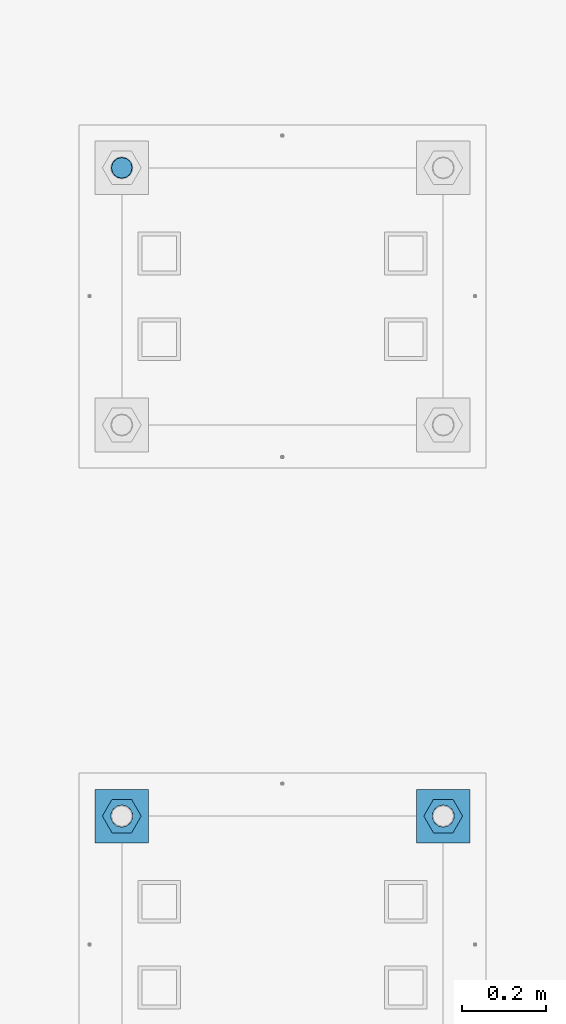
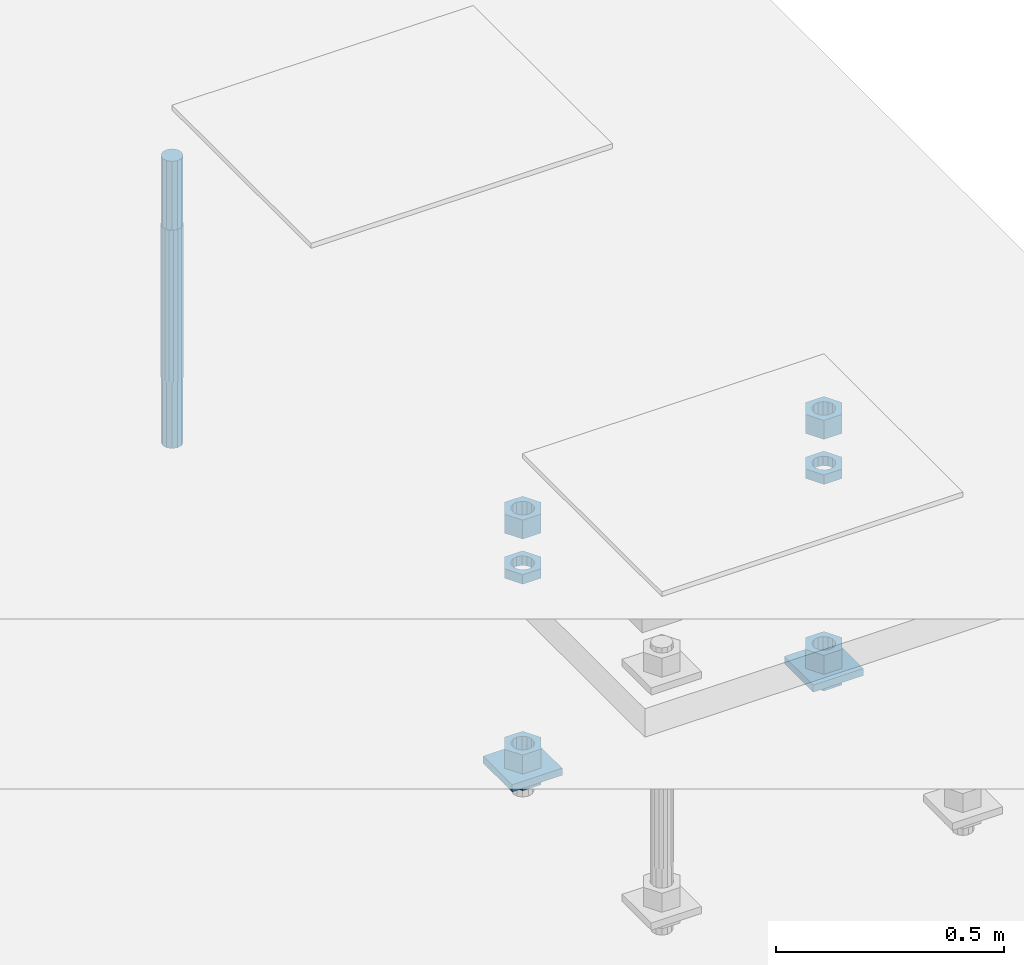
# One storey, part 2633 of 3843: 11 beams, 2 elements without a shape of their own.
"""IFC2X3 building model written with IfcOpenShell, lengths in millimetres."""

from ifc_helpers import new_model, si_unit, frame, origin_with_axes, place, context, subcontext, project, spatial, faceted_brep, material, type_object, element, aggregate, save


model = new_model("IFC2X3")

# Units and contexts
model_context = context("Model", 3, precision=1e-05, world=origin_with_axes())
body_context = subcontext(model_context, "Body", "Model", "MODEL_VIEW")
ifc_project = project(units=[si_unit("LENGTHUNIT", "METRE", prefix="MILLI"), si_unit("AREAUNIT", "SQUARE_METRE"), si_unit("VOLUMEUNIT", "CUBIC_METRE"), si_unit("MASSUNIT", "GRAM", prefix="KILO"), si_unit("TIMEUNIT", "SECOND"), si_unit("PLANEANGLEUNIT", "RADIAN"), si_unit("SOLIDANGLEUNIT", "STERADIAN"), si_unit("THERMODYNAMICTEMPERATUREUNIT", "DEGREE_CELSIUS"), si_unit("LUMINOUSINTENSITYUNIT", "LUMEN")], contexts=[model_context])

# Site, building, storey
site_placement = place(None, origin_with_axes())
site = spatial("IfcSite", under=ifc_project, at=site_placement, CompositionType="ELEMENT")
building_placement = place(site_placement, origin_with_axes())
building = spatial("IfcBuilding", under=site, at=building_placement, Name="Undefined", CompositionType="ELEMENT")
storey_placement = place(building_placement, origin_with_axes())
storey = spatial("IfcBuildingStorey", under=building, at=storey_placement, Name="Undefined", CompositionType="ELEMENT", Elevation=0.0)

# Assembly, beams
assembly_1_placement = place(storey_placement, origin_with_axes())
assembly_1 = element("IfcElementAssembly", 1, at=assembly_1_placement, inside=storey, Name="TEMPLATE", AssemblyPlace="NOTDEFINED", PredefinedType="RIGID_FRAME")
ifc_material_1 = material(Name="STEEL/A572-50")
beam_type_1 = type_object("IfcBeamType", PredefinedType="NOTDEFINED")
beam_1_placement = place(assembly_1_placement, frame((118465.6, 1892.30000152587, 29244.925), z_axis=(1.0, 0.0, 0.0), x_axis=(0.0, 1.0, 0.0)))
beam_1 = element("IfcBeam", 2, at=beam_1_placement, type_object=beam_type_1, material=ifc_material_1, Name="WASHER_PLATE", context=body_context, shape_type="Brep", body=[
    faceted_brep([(0.0, 9.52500000000146, -63.5), (0.0, 9.52500000000146, 63.5), (127.0, 9.52500000000146, 63.5), (127.0, 9.52500000000146, -63.5), (0.0, -9.52500000000146, 63.5), (127.0, -9.52500000000146, 63.5), (0.0, -9.52500000000146, -63.5), (127.0, -9.52500000000146, -63.5)], [[[0, 1, 2, 3]], [[1, 4, 5, 2]], [[4, 6, 7, 5]], [[6, 0, 3, 7]], [[5, 7, 3, 2]], [[6, 4, 1, 0]]]),
])
beam_2_placement = place(assembly_1_placement, frame((119227.6, 1892.30000152587, 29244.925), z_axis=(1.0, 0.0, 0.0), x_axis=(0.0, 1.0, 0.0)))
beam_2 = element("IfcBeam", 3, at=beam_2_placement, type_object=beam_type_1, material=ifc_material_1, Name="WASHER_PLATE", context=body_context, shape_type="Brep", body=[
    faceted_brep([(0.0, 9.52500000000146, -63.5), (0.0, 9.52500000000146, 63.5), (127.0, 9.52500000000146, 63.5), (127.0, 9.52500000000146, -63.5), (0.0, -9.52500000000146, 63.5), (127.0, -9.52500000000146, 63.5), (0.0, -9.52500000000146, -63.5), (127.0, -9.52500000000146, -63.5)], [[[0, 1, 2, 3]], [[1, 4, 5, 2]], [[4, 6, 7, 5]], [[6, 0, 3, 7]], [[5, 7, 3, 2]], [[6, 4, 1, 0]]]),
])
ifc_material_2 = material(Name="STEEL/A36")
beam_type_2 = type_object("IfcBeamType", Name="2_HALF_NUT", PredefinedType="NOTDEFINED")
beam_3_placement = place(assembly_1_placement, frame((118465.6, 1955.80000152587, 29787.85), z_axis=(0.0, 1.0, 0.0), x_axis=(0.0, 0.0, -1.0)))
beam_3 = element("IfcBeam", 4, at=beam_3_placement, type_object=beam_type_2, material=ifc_material_2, Name="NUT", ObjectType="2_HALF_NUT", context=body_context, shape_type="Brep", body=[
    faceted_brep([(0.0, -46.0369987487793, 0.0), (0.0, -23.0184993743896, -39.869213104248), (25.4000000000015, -23.0184993743896, -39.869213104248), (25.4000000000015, -46.0369987487793, 0.0), (0.0, 23.0184993743896, -39.869213104248), (25.4000000000015, 23.0184993743896, -39.869213104248), (0.0, 46.0369987487793, 0.0), (25.4000000000015, 46.0369987487793, 0.0), (0.0, 23.0184993743896, 39.869213104248), (25.4000000000015, 23.0184993743896, 39.869213104248), (0.0, -23.0184993743896, 39.869213104248), (25.4000000000015, -23.0184993743896, 39.869213104248), (0.0, 0.0, 26.1940002441406), (0.0, 11.3650617044477, 23.5999013092805), (25.4000000000015, 11.3650617044477, 23.5999013092805), (25.4000000000015, 0.0, 26.1940002441406), (0.0, 20.4791109456419, 16.3316083006721), (25.4000000000015, 20.4791109456419, 16.3316083006721), (0.0, 25.5370200498292, 5.82867859874386), (25.4000000000015, 25.5370200498292, 5.82867859874386), (0.0, 25.5370200498292, -5.82867859874386), (25.4000000000015, 25.5370200498292, -5.82867859874386), (0.0, 20.4791109456419, -16.3316083006721), (25.4000000000015, 20.4791109456419, -16.3316083006721), (0.0, 11.3650617044477, -23.5999013092805), (25.4000000000015, 11.3650617044477, -23.5999013092805), (0.0, 0.0, -26.1940002441406), (25.4000000000015, 0.0, -26.1940002441406), (0.0, -11.3650617044477, -23.5999013092805), (25.4000000000015, -11.3650617044477, -23.5999013092805), (0.0, -20.4791109456419, -16.3316083006721), (25.4000000000015, -20.4791109456419, -16.3316083006721), (0.0, -25.5370200498292, -5.82867859874386), (25.4000000000015, -25.5370200498292, -5.82867859874386), (0.0, -25.5370200498292, 5.82867859874386), (25.4000000000015, -25.5370200498292, 5.82867859874386), (0.0, -20.4791109456419, 16.3316083006721), (25.4000000000015, -20.4791109456419, 16.3316083006721), (0.0, -11.3650617044477, 23.5999013092805), (25.4000000000015, -11.3650617044477, 23.5999013092805)], [[[0, 1, 2, 3]], [[1, 4, 5, 2]], [[4, 6, 7, 5]], [[6, 8, 9, 7]], [[8, 10, 11, 9]], [[10, 0, 3, 11]], [[12, 13, 14, 15]], [[13, 16, 17, 14]], [[16, 18, 19, 17]], [[18, 20, 21, 19]], [[20, 22, 23, 21]], [[22, 24, 25, 23]], [[24, 26, 27, 25]], [[26, 28, 29, 27]], [[28, 30, 31, 29]], [[30, 32, 33, 31]], [[32, 34, 35, 33]], [[34, 36, 37, 35]], [[36, 38, 39, 37]], [[38, 12, 15, 39]], [[5, 7, 9, 11, 3, 2], [17, 19, 21, 23, 25, 27, 29, 31, 33, 35, 37, 39, 15, 14]], [[10, 8, 6, 4, 1, 0], [38, 36, 34, 32, 30, 28, 26, 24, 22, 20, 18, 16, 13, 12]]]),
])
beam_4_placement = place(assembly_1_placement, frame((118465.6, 1955.80000152587, 29235.4), z_axis=(0.0, 1.0, 0.0), x_axis=(0.0, 0.0, -1.0)))
beam_4 = element("IfcBeam", 5, at=beam_4_placement, type_object=beam_type_2, material=ifc_material_2, Name="NUT", ObjectType="2_HALF_NUT", context=body_context, shape_type="Brep", body=[
    faceted_brep([(0.0, -46.0369987487793, 0.0), (0.0, -23.0184993743896, -39.869213104248), (25.4000000000015, -23.0184993743896, -39.869213104248), (25.4000000000015, -46.0369987487793, 0.0), (0.0, 23.0184993743896, -39.869213104248), (25.4000000000015, 23.0184993743896, -39.869213104248), (0.0, 46.0369987487793, 0.0), (25.4000000000015, 46.0369987487793, 0.0), (0.0, 23.0184993743896, 39.869213104248), (25.4000000000015, 23.0184993743896, 39.869213104248), (0.0, -23.0184993743896, 39.869213104248), (25.4000000000015, -23.0184993743896, 39.869213104248), (0.0, 0.0, 26.1940002441406), (0.0, 11.3650617044477, 23.5999013092805), (25.4000000000015, 11.3650617044477, 23.5999013092805), (25.4000000000015, 0.0, 26.1940002441406), (0.0, 20.4791109456419, 16.3316083006721), (25.4000000000015, 20.4791109456419, 16.3316083006721), (0.0, 25.5370200498292, 5.82867859874386), (25.4000000000015, 25.5370200498292, 5.82867859874386), (0.0, 25.5370200498292, -5.82867859874386), (25.4000000000015, 25.5370200498292, -5.82867859874386), (0.0, 20.4791109456419, -16.3316083006721), (25.4000000000015, 20.4791109456419, -16.3316083006721), (0.0, 11.3650617044477, -23.5999013092805), (25.4000000000015, 11.3650617044477, -23.5999013092805), (0.0, 0.0, -26.1940002441406), (25.4000000000015, 0.0, -26.1940002441406), (0.0, -11.3650617044477, -23.5999013092805), (25.4000000000015, -11.3650617044477, -23.5999013092805), (0.0, -20.4791109456419, -16.3316083006721), (25.4000000000015, -20.4791109456419, -16.3316083006721), (0.0, -25.5370200498292, -5.82867859874386), (25.4000000000015, -25.5370200498292, -5.82867859874386), (0.0, -25.5370200498292, 5.82867859874386), (25.4000000000015, -25.5370200498292, 5.82867859874386), (0.0, -20.4791109456419, 16.3316083006721), (25.4000000000015, -20.4791109456419, 16.3316083006721), (0.0, -11.3650617044477, 23.5999013092805), (25.4000000000015, -11.3650617044477, 23.5999013092805)], [[[0, 1, 2, 3]], [[1, 4, 5, 2]], [[4, 6, 7, 5]], [[6, 8, 9, 7]], [[8, 10, 11, 9]], [[10, 0, 3, 11]], [[12, 13, 14, 15]], [[13, 16, 17, 14]], [[16, 18, 19, 17]], [[18, 20, 21, 19]], [[20, 22, 23, 21]], [[22, 24, 25, 23]], [[24, 26, 27, 25]], [[26, 28, 29, 27]], [[28, 30, 31, 29]], [[30, 32, 33, 31]], [[32, 34, 35, 33]], [[34, 36, 37, 35]], [[36, 38, 39, 37]], [[38, 12, 15, 39]], [[5, 7, 9, 11, 3, 2], [17, 19, 21, 23, 25, 27, 29, 31, 33, 35, 37, 39, 15, 14]], [[10, 8, 6, 4, 1, 0], [38, 36, 34, 32, 30, 28, 26, 24, 22, 20, 18, 16, 13, 12]]]),
])
beam_5_placement = place(assembly_1_placement, frame((119227.6, 1955.80000152587, 29787.85), z_axis=(0.0, 1.0, 0.0), x_axis=(0.0, 0.0, -1.0)))
beam_5 = element("IfcBeam", 6, at=beam_5_placement, type_object=beam_type_2, material=ifc_material_2, Name="NUT", ObjectType="2_HALF_NUT", context=body_context, shape_type="Brep", body=[
    faceted_brep([(0.0, -46.0369987487793, 0.0), (0.0, -23.0184993743896, -39.869213104248), (25.4000000000015, -23.0184993743896, -39.869213104248), (25.4000000000015, -46.0369987487793, 0.0), (0.0, 23.0184993743896, -39.869213104248), (25.4000000000015, 23.0184993743896, -39.869213104248), (0.0, 46.0369987487793, 0.0), (25.4000000000015, 46.0369987487793, 0.0), (0.0, 23.0184993743896, 39.869213104248), (25.4000000000015, 23.0184993743896, 39.869213104248), (0.0, -23.0184993743896, 39.869213104248), (25.4000000000015, -23.0184993743896, 39.869213104248), (0.0, 0.0, 26.1940002441406), (0.0, 11.3650617044477, 23.5999013092805), (25.4000000000015, 11.3650617044477, 23.5999013092805), (25.4000000000015, 0.0, 26.1940002441406), (0.0, 20.4791109456419, 16.3316083006721), (25.4000000000015, 20.4791109456419, 16.3316083006721), (0.0, 25.5370200498292, 5.82867859874386), (25.4000000000015, 25.5370200498292, 5.82867859874386), (0.0, 25.5370200498292, -5.82867859874386), (25.4000000000015, 25.5370200498292, -5.82867859874386), (0.0, 20.4791109456419, -16.3316083006721), (25.4000000000015, 20.4791109456419, -16.3316083006721), (0.0, 11.3650617044477, -23.5999013092805), (25.4000000000015, 11.3650617044477, -23.5999013092805), (0.0, 0.0, -26.1940002441406), (25.4000000000015, 0.0, -26.1940002441406), (0.0, -11.3650617044477, -23.5999013092805), (25.4000000000015, -11.3650617044477, -23.5999013092805), (0.0, -20.4791109456419, -16.3316083006721), (25.4000000000015, -20.4791109456419, -16.3316083006721), (0.0, -25.5370200498292, -5.82867859874386), (25.4000000000015, -25.5370200498292, -5.82867859874386), (0.0, -25.5370200498292, 5.82867859874386), (25.4000000000015, -25.5370200498292, 5.82867859874386), (0.0, -20.4791109456419, 16.3316083006721), (25.4000000000015, -20.4791109456419, 16.3316083006721), (0.0, -11.3650617044477, 23.5999013092805), (25.4000000000015, -11.3650617044477, 23.5999013092805)], [[[0, 1, 2, 3]], [[1, 4, 5, 2]], [[4, 6, 7, 5]], [[6, 8, 9, 7]], [[8, 10, 11, 9]], [[10, 0, 3, 11]], [[12, 13, 14, 15]], [[13, 16, 17, 14]], [[16, 18, 19, 17]], [[18, 20, 21, 19]], [[20, 22, 23, 21]], [[22, 24, 25, 23]], [[24, 26, 27, 25]], [[26, 28, 29, 27]], [[28, 30, 31, 29]], [[30, 32, 33, 31]], [[32, 34, 35, 33]], [[34, 36, 37, 35]], [[36, 38, 39, 37]], [[38, 12, 15, 39]], [[5, 7, 9, 11, 3, 2], [17, 19, 21, 23, 25, 27, 29, 31, 33, 35, 37, 39, 15, 14]], [[10, 8, 6, 4, 1, 0], [38, 36, 34, 32, 30, 28, 26, 24, 22, 20, 18, 16, 13, 12]]]),
])
beam_6_placement = place(assembly_1_placement, frame((119227.6, 1955.80000152587, 29235.4), z_axis=(0.0, 1.0, 0.0), x_axis=(0.0, 0.0, -1.0)))
beam_6 = element("IfcBeam", 7, at=beam_6_placement, type_object=beam_type_2, material=ifc_material_2, Name="NUT", ObjectType="2_HALF_NUT", context=body_context, shape_type="Brep", body=[
    faceted_brep([(0.0, -46.0369987487793, 0.0), (0.0, -23.0184993743896, -39.869213104248), (25.4000000000015, -23.0184993743896, -39.869213104248), (25.4000000000015, -46.0369987487793, 0.0), (0.0, 23.0184993743896, -39.869213104248), (25.4000000000015, 23.0184993743896, -39.869213104248), (0.0, 46.0369987487793, 0.0), (25.4000000000015, 46.0369987487793, 0.0), (0.0, 23.0184993743896, 39.869213104248), (25.4000000000015, 23.0184993743896, 39.869213104248), (0.0, -23.0184993743896, 39.869213104248), (25.4000000000015, -23.0184993743896, 39.869213104248), (0.0, 0.0, 26.1940002441406), (0.0, 11.3650617044477, 23.5999013092805), (25.4000000000015, 11.3650617044477, 23.5999013092805), (25.4000000000015, 0.0, 26.1940002441406), (0.0, 20.4791109456419, 16.3316083006721), (25.4000000000015, 20.4791109456419, 16.3316083006721), (0.0, 25.5370200498292, 5.82867859874386), (25.4000000000015, 25.5370200498292, 5.82867859874386), (0.0, 25.5370200498292, -5.82867859874386), (25.4000000000015, 25.5370200498292, -5.82867859874386), (0.0, 20.4791109456419, -16.3316083006721), (25.4000000000015, 20.4791109456419, -16.3316083006721), (0.0, 11.3650617044477, -23.5999013092805), (25.4000000000015, 11.3650617044477, -23.5999013092805), (0.0, 0.0, -26.1940002441406), (25.4000000000015, 0.0, -26.1940002441406), (0.0, -11.3650617044477, -23.5999013092805), (25.4000000000015, -11.3650617044477, -23.5999013092805), (0.0, -20.4791109456419, -16.3316083006721), (25.4000000000015, -20.4791109456419, -16.3316083006721), (0.0, -25.5370200498292, -5.82867859874386), (25.4000000000015, -25.5370200498292, -5.82867859874386), (0.0, -25.5370200498292, 5.82867859874386), (25.4000000000015, -25.5370200498292, 5.82867859874386), (0.0, -20.4791109456419, 16.3316083006721), (25.4000000000015, -20.4791109456419, 16.3316083006721), (0.0, -11.3650617044477, 23.5999013092805), (25.4000000000015, -11.3650617044477, 23.5999013092805)], [[[0, 1, 2, 3]], [[1, 4, 5, 2]], [[4, 6, 7, 5]], [[6, 8, 9, 7]], [[8, 10, 11, 9]], [[10, 0, 3, 11]], [[12, 13, 14, 15]], [[13, 16, 17, 14]], [[16, 18, 19, 17]], [[18, 20, 21, 19]], [[20, 22, 23, 21]], [[22, 24, 25, 23]], [[24, 26, 27, 25]], [[26, 28, 29, 27]], [[28, 30, 31, 29]], [[30, 32, 33, 31]], [[32, 34, 35, 33]], [[34, 36, 37, 35]], [[36, 38, 39, 37]], [[38, 12, 15, 39]], [[5, 7, 9, 11, 3, 2], [17, 19, 21, 23, 25, 27, 29, 31, 33, 35, 37, 39, 15, 14]], [[10, 8, 6, 4, 1, 0], [38, 36, 34, 32, 30, 28, 26, 24, 22, 20, 18, 16, 13, 12]]]),
])
beam_type_3 = type_object("IfcBeamType", Name="2_HEAVY_HEX_NUT", PredefinedType="NOTDEFINED")
beam_7_placement = place(assembly_1_placement, frame((118465.6, 1955.80000152587, 29933.9), z_axis=(0.0, 1.0, 0.0), x_axis=(0.0, 0.0, -1.0)))
beam_7 = element("IfcBeam", 8, at=beam_7_placement, type_object=beam_type_3, material=ifc_material_2, Name="NUT", ObjectType="2_HEAVY_HEX_NUT", context=body_context, shape_type="Brep", body=[
    faceted_brep([(0.0, -46.0369987487793, 0.0), (0.0, -23.0184993743896, -39.869213104248), (50.7999999999993, -23.0184993743896, -39.869213104248), (50.7999999999993, -46.0369987487793, 0.0), (0.0, 23.0184993743896, -39.869213104248), (50.7999999999993, 23.0184993743896, -39.869213104248), (0.0, 46.0369987487793, 0.0), (50.7999999999993, 46.0369987487793, 0.0), (0.0, 23.0184993743896, 39.869213104248), (50.7999999999993, 23.0184993743896, 39.869213104248), (0.0, -23.0184993743896, 39.869213104248), (50.7999999999993, -23.0184993743896, 39.869213104248), (0.0, 0.0, 26.1940002441406), (0.0, 11.3650617044477, 23.5999013092805), (50.7999999999993, 11.3650617044477, 23.5999013092805), (50.7999999999993, 0.0, 26.1940002441406), (0.0, 20.4791109456419, 16.3316083006721), (50.7999999999993, 20.4791109456419, 16.3316083006721), (0.0, 25.5370200498292, 5.82867859874386), (50.7999999999993, 25.5370200498292, 5.82867859874386), (0.0, 25.5370200498292, -5.82867859874386), (50.7999999999993, 25.5370200498292, -5.82867859874386), (0.0, 20.4791109456419, -16.3316083006721), (50.7999999999993, 20.4791109456419, -16.3316083006721), (0.0, 11.3650617044477, -23.5999013092805), (50.7999999999993, 11.3650617044477, -23.5999013092805), (0.0, 0.0, -26.1940002441406), (50.7999999999993, 0.0, -26.1940002441406), (0.0, -11.3650617044477, -23.5999013092805), (50.7999999999993, -11.3650617044477, -23.5999013092805), (0.0, -20.4791109456419, -16.3316083006721), (50.7999999999993, -20.4791109456419, -16.3316083006721), (0.0, -25.5370200498292, -5.82867859874386), (50.7999999999993, -25.5370200498292, -5.82867859874386), (0.0, -25.5370200498292, 5.82867859874386), (50.7999999999993, -25.5370200498292, 5.82867859874386), (0.0, -20.4791109456419, 16.3316083006721), (50.7999999999993, -20.4791109456419, 16.3316083006721), (0.0, -11.3650617044477, 23.5999013092805), (50.7999999999993, -11.3650617044477, 23.5999013092805)], [[[0, 1, 2, 3]], [[1, 4, 5, 2]], [[4, 6, 7, 5]], [[6, 8, 9, 7]], [[8, 10, 11, 9]], [[10, 0, 3, 11]], [[12, 13, 14, 15]], [[13, 16, 17, 14]], [[16, 18, 19, 17]], [[18, 20, 21, 19]], [[20, 22, 23, 21]], [[22, 24, 25, 23]], [[24, 26, 27, 25]], [[26, 28, 29, 27]], [[28, 30, 31, 29]], [[30, 32, 33, 31]], [[32, 34, 35, 33]], [[34, 36, 37, 35]], [[36, 38, 39, 37]], [[38, 12, 15, 39]], [[5, 7, 9, 11, 3, 2], [17, 19, 21, 23, 25, 27, 29, 31, 33, 35, 37, 39, 15, 14]], [[10, 8, 6, 4, 1, 0], [38, 36, 34, 32, 30, 28, 26, 24, 22, 20, 18, 16, 13, 12]]]),
])
beam_8_placement = place(assembly_1_placement, frame((118465.6, 1955.80000152587, 29305.25), z_axis=(0.0, 1.0, 0.0), x_axis=(0.0, 0.0, -1.0)))
beam_8 = element("IfcBeam", 9, at=beam_8_placement, type_object=beam_type_3, material=ifc_material_2, Name="NUT", ObjectType="2_HEAVY_HEX_NUT", context=body_context, shape_type="Brep", body=[
    faceted_brep([(0.0, -46.0369987487793, 0.0), (0.0, -23.0184993743896, -39.869213104248), (50.7999999999993, -23.0184993743896, -39.869213104248), (50.7999999999993, -46.0369987487793, 0.0), (0.0, 23.0184993743896, -39.869213104248), (50.7999999999993, 23.0184993743896, -39.869213104248), (0.0, 46.0369987487793, 0.0), (50.7999999999993, 46.0369987487793, 0.0), (0.0, 23.0184993743896, 39.869213104248), (50.7999999999993, 23.0184993743896, 39.869213104248), (0.0, -23.0184993743896, 39.869213104248), (50.7999999999993, -23.0184993743896, 39.869213104248), (0.0, 0.0, 26.1940002441406), (0.0, 11.3650617044477, 23.5999013092805), (50.7999999999993, 11.3650617044477, 23.5999013092805), (50.7999999999993, 0.0, 26.1940002441406), (0.0, 20.4791109456419, 16.3316083006721), (50.7999999999993, 20.4791109456419, 16.3316083006721), (0.0, 25.5370200498292, 5.82867859874386), (50.7999999999993, 25.5370200498292, 5.82867859874386), (0.0, 25.5370200498292, -5.82867859874386), (50.7999999999993, 25.5370200498292, -5.82867859874386), (0.0, 20.4791109456419, -16.3316083006721), (50.7999999999993, 20.4791109456419, -16.3316083006721), (0.0, 11.3650617044477, -23.5999013092805), (50.7999999999993, 11.3650617044477, -23.5999013092805), (0.0, 0.0, -26.1940002441406), (50.7999999999993, 0.0, -26.1940002441406), (0.0, -11.3650617044477, -23.5999013092805), (50.7999999999993, -11.3650617044477, -23.5999013092805), (0.0, -20.4791109456419, -16.3316083006721), (50.7999999999993, -20.4791109456419, -16.3316083006721), (0.0, -25.5370200498292, -5.82867859874386), (50.7999999999993, -25.5370200498292, -5.82867859874386), (0.0, -25.5370200498292, 5.82867859874386), (50.7999999999993, -25.5370200498292, 5.82867859874386), (0.0, -20.4791109456419, 16.3316083006721), (50.7999999999993, -20.4791109456419, 16.3316083006721), (0.0, -11.3650617044477, 23.5999013092805), (50.7999999999993, -11.3650617044477, 23.5999013092805)], [[[0, 1, 2, 3]], [[1, 4, 5, 2]], [[4, 6, 7, 5]], [[6, 8, 9, 7]], [[8, 10, 11, 9]], [[10, 0, 3, 11]], [[12, 13, 14, 15]], [[13, 16, 17, 14]], [[16, 18, 19, 17]], [[18, 20, 21, 19]], [[20, 22, 23, 21]], [[22, 24, 25, 23]], [[24, 26, 27, 25]], [[26, 28, 29, 27]], [[28, 30, 31, 29]], [[30, 32, 33, 31]], [[32, 34, 35, 33]], [[34, 36, 37, 35]], [[36, 38, 39, 37]], [[38, 12, 15, 39]], [[5, 7, 9, 11, 3, 2], [17, 19, 21, 23, 25, 27, 29, 31, 33, 35, 37, 39, 15, 14]], [[10, 8, 6, 4, 1, 0], [38, 36, 34, 32, 30, 28, 26, 24, 22, 20, 18, 16, 13, 12]]]),
])
beam_9_placement = place(assembly_1_placement, frame((119227.6, 1955.80000152587, 29933.9), z_axis=(0.0, 1.0, 0.0), x_axis=(0.0, 0.0, -1.0)))
beam_9 = element("IfcBeam", 10, at=beam_9_placement, type_object=beam_type_3, material=ifc_material_2, Name="NUT", ObjectType="2_HEAVY_HEX_NUT", context=body_context, shape_type="Brep", body=[
    faceted_brep([(0.0, -46.0369987487793, 0.0), (0.0, -23.0184993743896, -39.869213104248), (50.7999999999993, -23.0184993743896, -39.869213104248), (50.7999999999993, -46.0369987487793, 0.0), (0.0, 23.0184993743896, -39.869213104248), (50.7999999999993, 23.0184993743896, -39.869213104248), (0.0, 46.0369987487793, 0.0), (50.7999999999993, 46.0369987487793, 0.0), (0.0, 23.0184993743896, 39.869213104248), (50.7999999999993, 23.0184993743896, 39.869213104248), (0.0, -23.0184993743896, 39.869213104248), (50.7999999999993, -23.0184993743896, 39.869213104248), (0.0, 0.0, 26.1940002441406), (0.0, 11.3650617044477, 23.5999013092805), (50.7999999999993, 11.3650617044477, 23.5999013092805), (50.7999999999993, 0.0, 26.1940002441406), (0.0, 20.4791109456419, 16.3316083006721), (50.7999999999993, 20.4791109456419, 16.3316083006721), (0.0, 25.5370200498292, 5.82867859874386), (50.7999999999993, 25.5370200498292, 5.82867859874386), (0.0, 25.5370200498292, -5.82867859874386), (50.7999999999993, 25.5370200498292, -5.82867859874386), (0.0, 20.4791109456419, -16.3316083006721), (50.7999999999993, 20.4791109456419, -16.3316083006721), (0.0, 11.3650617044477, -23.5999013092805), (50.7999999999993, 11.3650617044477, -23.5999013092805), (0.0, 0.0, -26.1940002441406), (50.7999999999993, 0.0, -26.1940002441406), (0.0, -11.3650617044477, -23.5999013092805), (50.7999999999993, -11.3650617044477, -23.5999013092805), (0.0, -20.4791109456419, -16.3316083006721), (50.7999999999993, -20.4791109456419, -16.3316083006721), (0.0, -25.5370200498292, -5.82867859874386), (50.7999999999993, -25.5370200498292, -5.82867859874386), (0.0, -25.5370200498292, 5.82867859874386), (50.7999999999993, -25.5370200498292, 5.82867859874386), (0.0, -20.4791109456419, 16.3316083006721), (50.7999999999993, -20.4791109456419, 16.3316083006721), (0.0, -11.3650617044477, 23.5999013092805), (50.7999999999993, -11.3650617044477, 23.5999013092805)], [[[0, 1, 2, 3]], [[1, 4, 5, 2]], [[4, 6, 7, 5]], [[6, 8, 9, 7]], [[8, 10, 11, 9]], [[10, 0, 3, 11]], [[12, 13, 14, 15]], [[13, 16, 17, 14]], [[16, 18, 19, 17]], [[18, 20, 21, 19]], [[20, 22, 23, 21]], [[22, 24, 25, 23]], [[24, 26, 27, 25]], [[26, 28, 29, 27]], [[28, 30, 31, 29]], [[30, 32, 33, 31]], [[32, 34, 35, 33]], [[34, 36, 37, 35]], [[36, 38, 39, 37]], [[38, 12, 15, 39]], [[5, 7, 9, 11, 3, 2], [17, 19, 21, 23, 25, 27, 29, 31, 33, 35, 37, 39, 15, 14]], [[10, 8, 6, 4, 1, 0], [38, 36, 34, 32, 30, 28, 26, 24, 22, 20, 18, 16, 13, 12]]]),
])
beam_10_placement = place(assembly_1_placement, frame((119227.6, 1955.80000152587, 29305.25), z_axis=(0.0, 1.0, 0.0), x_axis=(0.0, 0.0, -1.0)))
beam_10 = element("IfcBeam", 11, at=beam_10_placement, type_object=beam_type_3, material=ifc_material_2, Name="NUT", ObjectType="2_HEAVY_HEX_NUT", context=body_context, shape_type="Brep", body=[
    faceted_brep([(0.0, -46.0369987487793, 0.0), (0.0, -23.0184993743896, -39.869213104248), (50.7999999999993, -23.0184993743896, -39.869213104248), (50.7999999999993, -46.0369987487793, 0.0), (0.0, 23.0184993743896, -39.869213104248), (50.7999999999993, 23.0184993743896, -39.869213104248), (0.0, 46.0369987487793, 0.0), (50.7999999999993, 46.0369987487793, 0.0), (0.0, 23.0184993743896, 39.869213104248), (50.7999999999993, 23.0184993743896, 39.869213104248), (0.0, -23.0184993743896, 39.869213104248), (50.7999999999993, -23.0184993743896, 39.869213104248), (0.0, 0.0, 26.1940002441406), (0.0, 11.3650617044477, 23.5999013092805), (50.7999999999993, 11.3650617044477, 23.5999013092805), (50.7999999999993, 0.0, 26.1940002441406), (0.0, 20.4791109456419, 16.3316083006721), (50.7999999999993, 20.4791109456419, 16.3316083006721), (0.0, 25.5370200498292, 5.82867859874386), (50.7999999999993, 25.5370200498292, 5.82867859874386), (0.0, 25.5370200498292, -5.82867859874386), (50.7999999999993, 25.5370200498292, -5.82867859874386), (0.0, 20.4791109456419, -16.3316083006721), (50.7999999999993, 20.4791109456419, -16.3316083006721), (0.0, 11.3650617044477, -23.5999013092805), (50.7999999999993, 11.3650617044477, -23.5999013092805), (0.0, 0.0, -26.1940002441406), (50.7999999999993, 0.0, -26.1940002441406), (0.0, -11.3650617044477, -23.5999013092805), (50.7999999999993, -11.3650617044477, -23.5999013092805), (0.0, -20.4791109456419, -16.3316083006721), (50.7999999999993, -20.4791109456419, -16.3316083006721), (0.0, -25.5370200498292, -5.82867859874386), (50.7999999999993, -25.5370200498292, -5.82867859874386), (0.0, -25.5370200498292, 5.82867859874386), (50.7999999999993, -25.5370200498292, 5.82867859874386), (0.0, -20.4791109456419, 16.3316083006721), (50.7999999999993, -20.4791109456419, 16.3316083006721), (0.0, -11.3650617044477, 23.5999013092805), (50.7999999999993, -11.3650617044477, 23.5999013092805)], [[[0, 1, 2, 3]], [[1, 4, 5, 2]], [[4, 6, 7, 5]], [[6, 8, 9, 7]], [[8, 10, 11, 9]], [[10, 0, 3, 11]], [[12, 13, 14, 15]], [[13, 16, 17, 14]], [[16, 18, 19, 17]], [[18, 20, 21, 19]], [[20, 22, 23, 21]], [[22, 24, 25, 23]], [[24, 26, 27, 25]], [[26, 28, 29, 27]], [[28, 30, 31, 29]], [[30, 32, 33, 31]], [[32, 34, 35, 33]], [[34, 36, 37, 35]], [[36, 38, 39, 37]], [[38, 12, 15, 39]], [[5, 7, 9, 11, 3, 2], [17, 19, 21, 23, 25, 27, 29, 31, 33, 35, 37, 39, 15, 14]], [[10, 8, 6, 4, 1, 0], [38, 36, 34, 32, 30, 28, 26, 24, 22, 20, 18, 16, 13, 12]]]),
])
aggregate(assembly_1, [beam_3, beam_7, beam_8, beam_4, beam_1, beam_5, beam_9, beam_10, beam_6, beam_2])

# Assembly, beam
assembly_2_placement = place(storey_placement, origin_with_axes())
assembly_2 = element("IfcElementAssembly", 12, at=assembly_2_placement, inside=storey, Name="TEMPLATE", AssemblyPlace="NOTDEFINED", PredefinedType="RIGID_FRAME")
ifc_material_3 = material()
beam_type_4 = type_object("IfcBeamType", PredefinedType="NOTDEFINED")
beam_11_placement = place(assembly_2_placement, frame((118465.600001526, 3492.49999999999, 29762.45), z_axis=(1.0, 0.0, 0.0), x_axis=(0.0, 0.0, -1.0)))
beam_11 = element("IfcBeam", 13, at=beam_11_placement, type_object=beam_type_4, material=ifc_material_3, Name="ANCHOR_ROD", context=body_context, shape_type="Brep", body=[
    faceted_brep([(0.0, -23.4665401257807, -9.72015918207035), (0.0, -17.9605122421344, -17.9605122421417), (406.399999999998, -17.9605122421344, -17.9605122421417), (406.399999999998, -23.4665401257807, -9.72015918207035), (0.0, -9.72015918207762, -23.466540125788), (406.399999999998, -9.72015918207762, -23.466540125788), (0.0, 0.0, -25.4000000000015), (406.399999999998, 0.0, -25.4000000000015), (0.0, 9.72015918207762, -23.466540125788), (406.399999999998, 9.72015918207762, -23.466540125788), (0.0, 17.9605122421344, -17.9605122421417), (406.399999999998, 17.9605122421344, -17.9605122421417), (0.0, 23.4665401257807, -9.72015918207035), (406.399999999998, 23.4665401257807, -9.72015918207035), (0.0, 25.3999996185303, 0.0), (406.399999999998, 25.3999999999942, 0.0), (0.0, 23.4665401257807, 9.72015918207035), (406.399999999998, 23.4665401257807, 9.72015918207035), (0.0, 17.9605122421344, 17.9605122421417), (406.399999999998, 17.9605122421344, 17.9605122421417), (0.0, 9.72015918207762, 23.466540125788), (406.399999999998, 9.72015918207762, 23.466540125788), (0.0, 0.0, 25.4000000000015), (406.399999999998, 0.0, 25.4000000000015), (0.0, -9.72015918207762, 23.466540125788), (406.399999999998, -9.72015918207762, 23.466540125788), (0.0, -17.9605122421344, 17.9605122421417), (406.399999999998, -17.9605122421344, 17.9605122421417), (0.0, -23.4665401257807, 9.72015918207035), (406.399999999998, -23.4665401257807, 9.72015918207035), (0.0, -25.3999996185303, 0.0), (406.399999999998, -25.3999999999942, 0.0), (584.200000000001, -12.2499999999854, -21.2176223927163), (584.200000000001, 1.45519152283669e-11, -24.5), (584.200000000001, 12.2500000000146, -21.2176223927163), (584.200000000001, 21.2176223927381, -12.25), (584.200000000001, 24.5000000000146, 0.0), (584.200000000001, 21.2176223927381, 12.25), (584.200000000001, 12.2500000000146, 21.2176223927163), (584.200000000001, 1.45519152283669e-11, 24.5), (584.200000000001, -12.2499999999854, 21.2176223927163), (584.200000000001, -21.217622392709, 12.25), (584.200000000001, -24.4999999999854, 0.0), (584.200000000001, -21.217622392709, -12.25), (406.399999999998, -24.4999999999854, 0.0), (406.399999999998, -21.217622392709, -12.25), (406.399999999998, -12.2499999999854, -21.2176223927163), (406.399999999998, 1.45519152283669e-11, -24.5), (406.399999999998, 12.2500000000146, -21.2176223927163), (406.399999999998, 21.2176223927381, -12.25), (406.399999999998, 24.5000000000146, 0.0), (406.399999999998, 21.2176223927381, 12.25), (406.399999999998, 12.2500000000146, 21.2176223927163), (406.399999999998, 1.45519152283669e-11, 24.5), (406.399999999998, -12.2499999999854, 21.2176223927163), (406.399999999998, -21.217622392709, 12.25), (0.0, 12.2500000000146, 21.2176223927163), (0.0, 1.45519152283669e-11, 24.5), (0.0, -12.2499999999854, 21.2176223927163), (0.0, -21.217622392709, 12.25), (0.0, -24.4999999999854, 0.0), (0.0, -21.217622392709, -12.25), (0.0, -12.2499999999854, -21.2176223927163), (0.0, 1.45519152283669e-11, -24.5), (0.0, 12.2500000000146, -21.2176223927163), (0.0, 21.2176223927381, -12.25), (0.0, 24.5000000000146, 0.0), (0.0, 21.2176223927381, 12.25), (-184.150000000001, -21.217622392709, 12.25), (-184.150000000001, -12.2499999999854, 21.2176223927163), (-184.150000000001, 1.45519152283669e-11, 24.5), (-184.150000000001, 12.2500000000146, 21.2176223927163), (-184.150000000001, 21.2176223927381, 12.25), (-184.150000000001, 24.5000000000146, 0.0), (-184.150000000001, 21.2176223927381, -12.25), (-184.150000000001, 12.2500000000146, -21.2176223927163), (-184.150000000001, 1.45519152283669e-11, -24.5), (-184.150000000001, -12.2499999999854, -21.2176223927163), (-184.150000000001, -21.217622392709, -12.25), (-184.150000000001, -24.4999999999854, 0.0)], [[[0, 1, 2, 3]], [[1, 4, 5, 2]], [[4, 6, 7, 5]], [[6, 8, 9, 7]], [[8, 10, 11, 9]], [[10, 12, 13, 11]], [[12, 14, 15, 13]], [[14, 16, 17, 15]], [[16, 18, 19, 17]], [[18, 20, 21, 19]], [[20, 22, 23, 21]], [[22, 24, 25, 23]], [[24, 26, 27, 25]], [[26, 28, 29, 27]], [[28, 30, 31, 29]], [[32, 33, 34, 35, 36, 37, 38, 39, 40, 41, 42, 43]], [[43, 42, 44, 45]], [[32, 43, 45, 46]], [[33, 32, 46, 47]], [[34, 33, 47, 48]], [[35, 34, 48, 49]], [[36, 35, 49, 50]], [[37, 36, 50, 51]], [[38, 37, 51, 52]], [[39, 38, 52, 53]], [[40, 39, 53, 54]], [[41, 40, 54, 55]], [[42, 41, 55, 44]], [[2, 5, 7, 9, 11, 13, 15, 17, 19, 21, 23, 25, 27, 29, 31, 3], [54, 53, 52, 51, 50, 49, 48, 47, 46, 45, 44, 55]], [[30, 0, 3, 31]], [[28, 26, 24, 22, 20, 18, 16, 14, 12, 10, 8, 6, 4, 1, 0, 30], [56, 57, 58, 59, 60, 61, 62, 63, 64, 65, 66, 67]], [[68, 69, 70, 71, 72, 73, 74, 75, 76, 77, 78, 79]], [[71, 70, 57, 56]], [[72, 71, 56, 67]], [[73, 72, 67, 66]], [[74, 73, 66, 65]], [[75, 74, 65, 64]], [[76, 75, 64, 63]], [[77, 76, 63, 62]], [[78, 77, 62, 61]], [[79, 78, 61, 60]], [[68, 79, 60, 59]], [[69, 68, 59, 58]], [[70, 69, 58, 57]]]),
])
aggregate(assembly_2, [beam_11])

save(model, "model.ifc")
